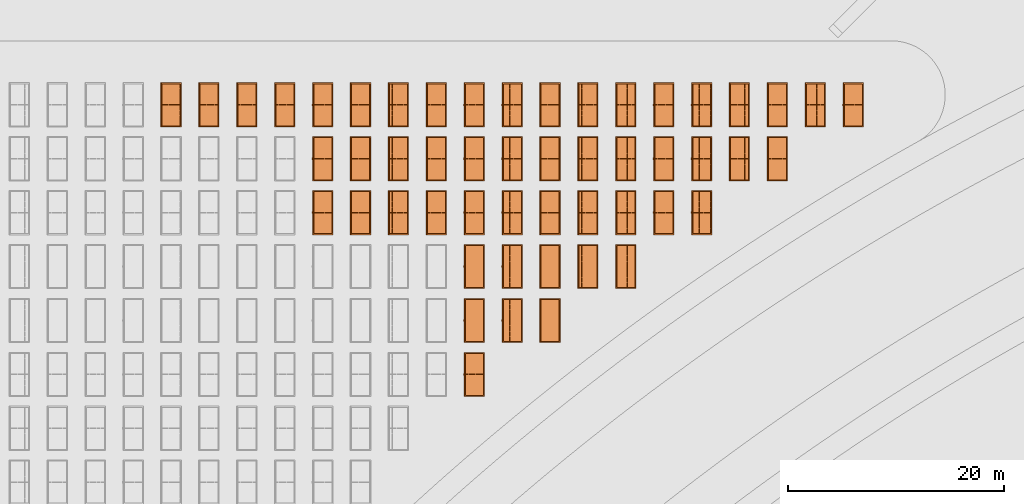
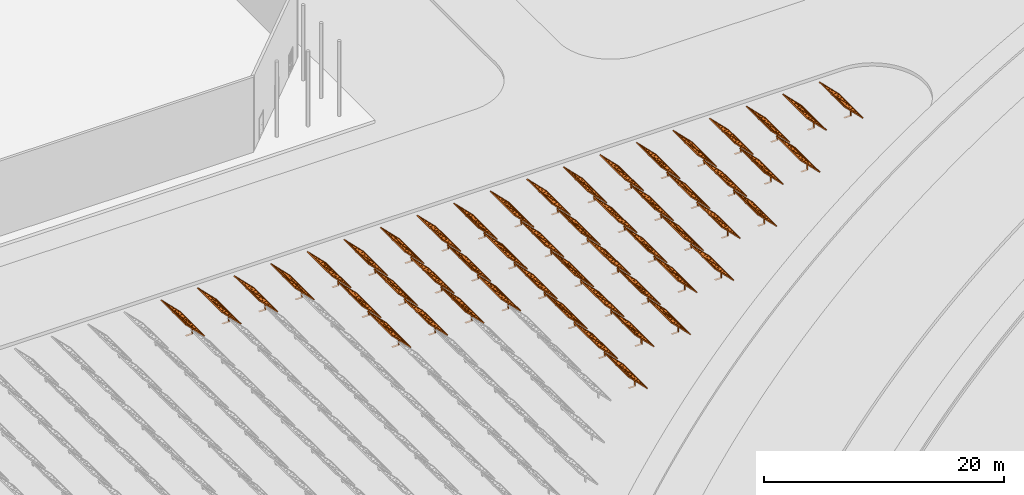
# One storey, part 38 of 39: 52 proxies.
"""IFC2X3 building model written with IfcOpenShell, lengths in millimetres."""

from ifc_helpers import new_model, entity, si_unit, converted_unit, derived_unit, direction, frame, frame_2d, origin, origin_2d_with_axis, place, context, subcontext, project, spatial, polyline, rectangle, outline, extrude, source, transform, mapped, material, material_list, element, save


model = new_model("IFC2X3")

# Units and contexts
model_context = context("Model", 3, precision=1e-06, world=origin(), true_north=direction((2.0, 6.12303176911189e-17, 1.0)))
context_of_model = context(None, 3, precision=1e-06, world=origin(), true_north=direction((2.0, 6.12303176911189e-17, 1.0)))
body_context = subcontext(model_context, "Body", "Model", "MODEL_VIEW")
ifc_project = project(units=[si_unit("LENGTHUNIT", "METRE", prefix="MILLI"), si_unit("AREAUNIT", "SQUARE_METRE", prefix="MILLI"), si_unit("VOLUMEUNIT", "CUBIC_METRE", prefix="MILLI"), converted_unit("PLANEANGLEUNIT", "DEGREE", entity("IfcRatioMeasure", 0.0174532925199433), si_unit("PLANEANGLEUNIT", "RADIAN"), dimensions=[0, 0, 0, 0, 0, 0, 0]), si_unit("MASSUNIT", "GRAM", prefix="KILO"), si_unit("TIMEUNIT", "SECOND"), si_unit("THERMODYNAMICTEMPERATUREUNIT", "KELVIN"), derived_unit("THERMALTRANSMITTANCEUNIT", [(si_unit("MASSUNIT", "GRAM", prefix="KILO"), 1), (si_unit("THERMODYNAMICTEMPERATUREUNIT", "KELVIN"), -1), (si_unit("TIMEUNIT", "SECOND"), -3)]), derived_unit("VOLUMETRICFLOWRATEUNIT", [(si_unit("LENGTHUNIT", "METRE"), 3), (si_unit("TIMEUNIT", "SECOND"), -1)])], contexts=[model_context, context_of_model])

# Site, building, storey
site_placement = place(None, origin())
site = spatial("IfcSite", under=ifc_project, at=site_placement, CompositionType="ELEMENT")
building_placement = place(site_placement, origin())
building = spatial("IfcBuilding", under=site, at=building_placement, CompositionType="ELEMENT")
storey_placement = place(building_placement, frame((0.0, 0.0, 4000.0)))
storey = spatial("IfcBuildingStorey", under=building, at=storey_placement, Name="Level 2", CompositionType="ELEMENT", Elevation=4000.0)

# Proxies
ifc_material_1 = material(Name="Stand-Steel")
ifc_material_2 = material(Name="Aluminium")
ifc_material_3 = material(Name="Glass")
ifc_material_list_1 = material_list([ifc_material_1, ifc_material_2, ifc_material_3])
shared_shape = source(origin(), body_context, "Body", "SweptSolid", [
    extrude(outline(polyline([(-629.526235435404, -220.0), (329.763117717702, -220.0), (329.763117717703, 410.0), (299.763117717703, 410.0), (299.763117717702, -190.0), (-629.526235435404, -190.0), (-629.526235435404, -220.0)])), frame((-190.00003127179, -100.0, 299.763117717707), z_axis=(0.0, 1.0, 0.0), x_axis=(0.0, 0.0, -1.0)), (0.0, 0.0, 1.0), 200.0),
    extrude(rectangle(XDim=20.0000000000001, YDim=200.0, at=frame_2d((0.0, -7.105427357601e-14), x_axis=(0.0, 1.0))), frame((-7.07109908365613, 0.0, 922.21828534124), z_axis=(-0.70710678118654, 0.0, 0.707106781186555), x_axis=(0.0, 1.0, 0.0)), (0.0, 0.0, 1.0), 2600.0),
    extrude(rectangle(XDim=24.9999999999997, YDim=24.9999999999999, at=frame_2d((2.87769807982841e-13, -9.50350909079134e-14), x_axis=(1.0, 0.0))), frame((-1449.56292018118, -1950.0, 2449.57494522722), z_axis=(0.0, 1.0, 0.0), x_axis=(-0.707106781186548, 0.0, -0.707106781186548)), (0.0, 0.0, 1.0), 3900.0),
    extrude(rectangle(XDim=24.9999999999999, YDim=25.0000000000001, at=origin_2d_with_axis()), frame((-1096.0095295879, -1950.0, 2096.02155463395), z_axis=(0.0, 1.0, 0.0), x_axis=(-0.707106781186542, 0.0, -0.707106781186553)), (0.0, 0.0, 1.0), 3900.0),
    extrude(rectangle(XDim=24.9999999999999, YDim=25.0000000000001, at=origin_2d_with_axis()), frame((-742.456138994631, -1950.0, 1742.46816404067), z_axis=(0.0, 1.0, 0.0), x_axis=(-0.707106781186542, 0.0, -0.707106781186553)), (0.0, 0.0, 1.0), 3900.0),
    extrude(rectangle(XDim=25.0, YDim=24.9999999999997, at=frame_2d((-7.19424519957101e-14, 1.19904086659517e-13), x_axis=(1.0, 0.0))), frame((-388.902748401358, -1950.0, 1388.9147734474), z_axis=(0.0, 1.0, 0.0), x_axis=(-0.707106781186545, 0.0, -0.70710678118655)), (0.0, 0.0, 1.0), 3900.0),
    extrude(rectangle(XDim=25.0000000000002, YDim=25.0, at=frame_2d((1.35891298214119e-13, 6.21724893790088e-15), x_axis=(0.0, 1.0))), frame((-35.3553703311048, 1500.0, 1035.35537033109), z_axis=(-0.707106781186544, 0.0, 0.707106781186551), x_axis=(0.0, 1.0, 0.0)), (0.0, 0.0, 1.0), 2440.0),
    extrude(rectangle(XDim=25.0000000000002, YDim=25.0, at=frame_2d((0.0, 1.77635683940025e-15), x_axis=(0.0, 1.0))), frame((-35.3553703311059, 1000.0, 1035.35537033109), z_axis=(-0.707106781186546, 0.0, 0.707106781186549), x_axis=(0.0, 1.0, 0.0)), (0.0, 0.0, 1.0), 2440.0),
    extrude(rectangle(XDim=25.0000000000002, YDim=25.0, at=frame_2d((0.0, 8.43769498715119e-14), x_axis=(0.0, 1.0))), frame((-26.5165355662756, 0.0, 1044.19420509593), z_axis=(-0.707106781186546, 0.0, 0.707106781186549), x_axis=(0.0, -1.0, 0.0)), (0.0, 0.0, 1.0), 2440.0),
    extrude(rectangle(XDim=25.0000000000002, YDim=25.0, at=frame_2d((0.0, 8.88178419700125e-16), x_axis=(0.0, 1.0))), frame((-35.3553703311065, 500.0, 1035.35537033109), z_axis=(-0.707106781186546, 0.0, 0.707106781186549), x_axis=(0.0, 1.0, 0.0)), (0.0, 0.0, 1.0), 2440.0),
    extrude(rectangle(XDim=25.0000000000002, YDim=25.0, at=frame_2d((0.0, 8.88178419700125e-16), x_axis=(0.0, 1.0))), frame((-35.3553703311086, -500.0, 1035.35537033109), z_axis=(-0.707106781186546, 0.0, 0.707106781186549), x_axis=(0.0, 1.0, 0.0)), (0.0, 0.0, 1.0), 2440.0),
    extrude(rectangle(XDim=25.0000000000002, YDim=25.0, at=frame_2d((0.0, 8.88178419700125e-16), x_axis=(0.0, 1.0))), frame((-35.3553703311095, -1000.0, 1035.35537033109), z_axis=(-0.707106781186546, 0.0, 0.707106781186549), x_axis=(0.0, 1.0, 0.0)), (0.0, 0.0, 1.0), 2440.0),
    extrude(rectangle(XDim=25.0000000000002, YDim=25.0, at=frame_2d((1.35891298214119e-13, 1.77635683940025e-15), x_axis=(0.0, 1.0))), frame((-35.3553703311107, -1500.0, 1035.35537033109), z_axis=(-0.707106781186546, 0.0, 0.707106781186549), x_axis=(0.0, 1.0, 0.0)), (0.0, 0.0, 1.0), 2440.0),
    extrude(rectangle(XDim=2400.0, YDim=11.9999999999994, at=frame_2d((-1.13686837721616e-13, 2.02948768901479e-13), x_axis=(1.0, 0.0))), frame((-883.883507754966, -1950.0, 1883.88350775495), z_axis=(0.0, 1.0, 0.0), x_axis=(0.707106781186546, 0.0, -0.707106781186549)), (0.0, 0.0, 1.0), 3900.0),
    extrude(outline(polyline([(-2050.0, -1300.0), (2050.0, -1300.0), (2050.0, 1300.0), (-2050.0, 1300.0), (-2050.0, -1300.0)]), holes=[polyline([(1950.0, -1200.0), (-1950.0, -1200.0), (-1950.0, 1200.0), (1950.0, 1200.0), (1950.0, -1200.0)])]), frame((-919.238846814293, 0.0, 1848.52816869563), z_axis=(0.707106781186554, 0.0, 0.707106781186541), x_axis=(0.0, 1.0, 0.0)), (0.0, 0.0, 1.0), 99.9999999999898),
])
proxy_1_placement = place(storey_placement, frame((-76070.1519924236, 685144.680552408, 30.0)))
element("IfcBuildingElementProxy", 1, at=proxy_1_placement, inside=storey, material=ifc_material_list_1, Name="Solar Panel_4000X2500:Solar Panel_4000X2500", ObjectType="Solar Panel_4000X2500", CompositionType="ELEMENT", context=body_context, shape_type="MappedRepresentation", body=[
    mapped(shared_shape, transform((0.0, 0.0, 0.0), scale=1.0)),
])
ifc_material_list_2 = material_list([ifc_material_1, ifc_material_2, ifc_material_3])
proxy_2_placement = place(storey_placement, frame((-72555.1416206938, 685144.680552408, 30.0)))
element("IfcBuildingElementProxy", 2, at=proxy_2_placement, inside=storey, material=ifc_material_list_2, Name="Solar Panel_4000X2500:Solar Panel_4000X2500", ObjectType="Solar Panel_4000X2500", CompositionType="ELEMENT", context=body_context, shape_type="MappedRepresentation", body=[
    mapped(shared_shape, transform((0.0, 0.0, 0.0), scale=1.0)),
])
ifc_material_list_3 = material_list([ifc_material_1, ifc_material_2, ifc_material_3])
proxy_3_placement = place(storey_placement, frame((-69040.131248964, 685144.680552408, 30.0)))
element("IfcBuildingElementProxy", 3, at=proxy_3_placement, inside=storey, material=ifc_material_list_3, Name="Solar Panel_4000X2500:Solar Panel_4000X2500", ObjectType="Solar Panel_4000X2500", CompositionType="ELEMENT", context=body_context, shape_type="MappedRepresentation", body=[
    mapped(shared_shape, transform((0.0, 0.0, 0.0), scale=1.0)),
])
ifc_material_list_4 = material_list([ifc_material_1, ifc_material_2, ifc_material_3])
proxy_4_placement = place(storey_placement, frame((-65525.1208772342, 685144.680552408, 30.0)))
element("IfcBuildingElementProxy", 4, at=proxy_4_placement, inside=storey, material=ifc_material_list_4, Name="Solar Panel_4000X2500:Solar Panel_4000X2500", ObjectType="Solar Panel_4000X2500", CompositionType="ELEMENT", context=body_context, shape_type="MappedRepresentation", body=[
    mapped(shared_shape, transform((0.0, 0.0, 0.0), scale=1.0)),
])
ifc_material_list_5 = material_list([ifc_material_1, ifc_material_2, ifc_material_3])
proxy_5_placement = place(storey_placement, frame((-62010.1105055045, 675144.680552408, 30.0)))
element("IfcBuildingElementProxy", 5, at=proxy_5_placement, inside=storey, material=ifc_material_list_5, Name="Solar Panel_4000X2500:Solar Panel_4000X2500", ObjectType="Solar Panel_4000X2500", CompositionType="ELEMENT", context=body_context, shape_type="MappedRepresentation", body=[
    mapped(shared_shape, transform((0.0, 0.0, 0.0), scale=1.0)),
])
ifc_material_list_6 = material_list([ifc_material_1, ifc_material_2, ifc_material_3])
proxy_6_placement = place(storey_placement, frame((-58495.1001337747, 675144.680552408, 30.0)))
element("IfcBuildingElementProxy", 6, at=proxy_6_placement, inside=storey, material=ifc_material_list_6, Name="Solar Panel_4000X2500:Solar Panel_4000X2500", ObjectType="Solar Panel_4000X2500", CompositionType="ELEMENT", context=body_context, shape_type="MappedRepresentation", body=[
    mapped(shared_shape, transform((0.0, 0.0, 0.0), scale=1.0)),
])
ifc_material_list_7 = material_list([ifc_material_1, ifc_material_2, ifc_material_3])
proxy_7_placement = place(storey_placement, frame((-54980.0897620449, 675144.680552408, 30.0)))
element("IfcBuildingElementProxy", 7, at=proxy_7_placement, inside=storey, material=ifc_material_list_7, Name="Solar Panel_4000X2500:Solar Panel_4000X2500", ObjectType="Solar Panel_4000X2500", CompositionType="ELEMENT", context=body_context, shape_type="MappedRepresentation", body=[
    mapped(shared_shape, transform((0.0, 0.0, 0.0), scale=1.0)),
])
ifc_material_list_8 = material_list([ifc_material_1, ifc_material_2, ifc_material_3])
proxy_8_placement = place(storey_placement, frame((-51465.0793903151, 675144.680552408, 30.0)))
element("IfcBuildingElementProxy", 8, at=proxy_8_placement, inside=storey, material=ifc_material_list_8, Name="Solar Panel_4000X2500:Solar Panel_4000X2500", ObjectType="Solar Panel_4000X2500", CompositionType="ELEMENT", context=body_context, shape_type="MappedRepresentation", body=[
    mapped(shared_shape, transform((0.0, 0.0, 0.0), scale=1.0)),
])
ifc_material_list_9 = material_list([ifc_material_1, ifc_material_2, ifc_material_3])
proxy_9_placement = place(storey_placement, frame((-62010.1105055045, 680144.680552408, 30.0)))
element("IfcBuildingElementProxy", 9, at=proxy_9_placement, inside=storey, material=ifc_material_list_9, Name="Solar Panel_4000X2500:Solar Panel_4000X2500", ObjectType="Solar Panel_4000X2500", CompositionType="ELEMENT", context=body_context, shape_type="MappedRepresentation", body=[
    mapped(shared_shape, transform((0.0, 0.0, 0.0), scale=1.0)),
])
ifc_material_list_10 = material_list([ifc_material_1, ifc_material_2, ifc_material_3])
proxy_10_placement = place(storey_placement, frame((-58495.1001337747, 680144.680552408, 30.0)))
element("IfcBuildingElementProxy", 10, at=proxy_10_placement, inside=storey, material=ifc_material_list_10, Name="Solar Panel_4000X2500:Solar Panel_4000X2500", ObjectType="Solar Panel_4000X2500", CompositionType="ELEMENT", context=body_context, shape_type="MappedRepresentation", body=[
    mapped(shared_shape, transform((0.0, 0.0, 0.0), scale=1.0)),
])
ifc_material_list_11 = material_list([ifc_material_1, ifc_material_2, ifc_material_3])
proxy_11_placement = place(storey_placement, frame((-54980.0897620449, 680144.680552408, 30.0)))
element("IfcBuildingElementProxy", 11, at=proxy_11_placement, inside=storey, material=ifc_material_list_11, Name="Solar Panel_4000X2500:Solar Panel_4000X2500", ObjectType="Solar Panel_4000X2500", CompositionType="ELEMENT", context=body_context, shape_type="MappedRepresentation", body=[
    mapped(shared_shape, transform((0.0, 0.0, 0.0), scale=1.0)),
])
ifc_material_list_12 = material_list([ifc_material_1, ifc_material_2, ifc_material_3])
proxy_12_placement = place(storey_placement, frame((-51465.0793903151, 680144.680552408, 30.0)))
element("IfcBuildingElementProxy", 12, at=proxy_12_placement, inside=storey, material=ifc_material_list_12, Name="Solar Panel_4000X2500:Solar Panel_4000X2500", ObjectType="Solar Panel_4000X2500", CompositionType="ELEMENT", context=body_context, shape_type="MappedRepresentation", body=[
    mapped(shared_shape, transform((0.0, 0.0, 0.0), scale=1.0)),
])
ifc_material_list_13 = material_list([ifc_material_1, ifc_material_2, ifc_material_3])
proxy_13_placement = place(storey_placement, frame((-62010.1105055044, 685144.680552408, 30.0)))
element("IfcBuildingElementProxy", 13, at=proxy_13_placement, inside=storey, material=ifc_material_list_13, Name="Solar Panel_4000X2500:Solar Panel_4000X2500", ObjectType="Solar Panel_4000X2500", CompositionType="ELEMENT", context=body_context, shape_type="MappedRepresentation", body=[
    mapped(shared_shape, transform((0.0, 0.0, 0.0), scale=1.0)),
])
ifc_material_list_14 = material_list([ifc_material_1, ifc_material_2, ifc_material_3])
proxy_14_placement = place(storey_placement, frame((-58495.1001337746, 685144.680552408, 30.0)))
element("IfcBuildingElementProxy", 14, at=proxy_14_placement, inside=storey, material=ifc_material_list_14, Name="Solar Panel_4000X2500:Solar Panel_4000X2500", ObjectType="Solar Panel_4000X2500", CompositionType="ELEMENT", context=body_context, shape_type="MappedRepresentation", body=[
    mapped(shared_shape, transform((0.0, 0.0, 0.0), scale=1.0)),
])
ifc_material_list_15 = material_list([ifc_material_1, ifc_material_2, ifc_material_3])
proxy_15_placement = place(storey_placement, frame((-54980.0897620449, 685144.680552408, 30.0)))
element("IfcBuildingElementProxy", 15, at=proxy_15_placement, inside=storey, material=ifc_material_list_15, Name="Solar Panel_4000X2500:Solar Panel_4000X2500", ObjectType="Solar Panel_4000X2500", CompositionType="ELEMENT", context=body_context, shape_type="MappedRepresentation", body=[
    mapped(shared_shape, transform((0.0, 0.0, 0.0), scale=1.0)),
])
ifc_material_list_16 = material_list([ifc_material_1, ifc_material_2, ifc_material_3])
proxy_16_placement = place(storey_placement, frame((-51465.0793903151, 685144.680552408, 30.0)))
element("IfcBuildingElementProxy", 16, at=proxy_16_placement, inside=storey, material=ifc_material_list_16, Name="Solar Panel_4000X2500:Solar Panel_4000X2500", ObjectType="Solar Panel_4000X2500", CompositionType="ELEMENT", context=body_context, shape_type="MappedRepresentation", body=[
    mapped(shared_shape, transform((0.0, 0.0, 0.0), scale=1.0)),
])
ifc_material_list_17 = material_list([ifc_material_1, ifc_material_2, ifc_material_3])
proxy_17_placement = place(storey_placement, frame((-47950.0690185853, 660144.680552408, 30.0)))
element("IfcBuildingElementProxy", 17, at=proxy_17_placement, inside=storey, material=ifc_material_list_17, Name="Solar Panel_4000X2500:Solar Panel_4000X2500", ObjectType="Solar Panel_4000X2500", CompositionType="ELEMENT", context=body_context, shape_type="MappedRepresentation", body=[
    mapped(shared_shape, transform((0.0, 0.0, 0.0), scale=1.0)),
])
ifc_material_list_18 = material_list([ifc_material_1, ifc_material_2, ifc_material_3])
proxy_18_placement = place(storey_placement, frame((-47950.0690185853, 665144.680552408, 30.0)))
element("IfcBuildingElementProxy", 18, at=proxy_18_placement, inside=storey, material=ifc_material_list_18, Name="Solar Panel_4000X2500:Solar Panel_4000X2500", ObjectType="Solar Panel_4000X2500", CompositionType="ELEMENT", context=body_context, shape_type="MappedRepresentation", body=[
    mapped(shared_shape, transform((0.0, 0.0, 0.0), scale=1.0)),
])
ifc_material_list_19 = material_list([ifc_material_1, ifc_material_2, ifc_material_3])
proxy_19_placement = place(storey_placement, frame((-44435.0586468555, 665144.680552408, 30.0)))
element("IfcBuildingElementProxy", 19, at=proxy_19_placement, inside=storey, material=ifc_material_list_19, Name="Solar Panel_4000X2500:Solar Panel_4000X2500", ObjectType="Solar Panel_4000X2500", CompositionType="ELEMENT", context=body_context, shape_type="MappedRepresentation", body=[
    mapped(shared_shape, transform((0.0, 0.0, 0.0), scale=1.0)),
])
ifc_material_list_20 = material_list([ifc_material_1, ifc_material_2, ifc_material_3])
proxy_20_placement = place(storey_placement, frame((-40920.0482751257, 665144.680552408, 30.0)))
element("IfcBuildingElementProxy", 20, at=proxy_20_placement, inside=storey, material=ifc_material_list_20, Name="Solar Panel_4000X2500:Solar Panel_4000X2500", ObjectType="Solar Panel_4000X2500", CompositionType="ELEMENT", context=body_context, shape_type="MappedRepresentation", body=[
    mapped(shared_shape, transform((0.0, 0.0, 0.0), scale=1.0)),
])
ifc_material_list_21 = material_list([ifc_material_1, ifc_material_2, ifc_material_3])
proxy_21_placement = place(storey_placement, frame((-47950.0690185853, 670144.680552408, 30.0)))
element("IfcBuildingElementProxy", 21, at=proxy_21_placement, inside=storey, material=ifc_material_list_21, Name="Solar Panel_4000X2500:Solar Panel_4000X2500", ObjectType="Solar Panel_4000X2500", CompositionType="ELEMENT", context=body_context, shape_type="MappedRepresentation", body=[
    mapped(shared_shape, transform((0.0, 0.0, 0.0), scale=1.0)),
])
ifc_material_list_22 = material_list([ifc_material_1, ifc_material_2, ifc_material_3])
proxy_22_placement = place(storey_placement, frame((-44435.0586468555, 670144.680552408, 30.0)))
element("IfcBuildingElementProxy", 22, at=proxy_22_placement, inside=storey, material=ifc_material_list_22, Name="Solar Panel_4000X2500:Solar Panel_4000X2500", ObjectType="Solar Panel_4000X2500", CompositionType="ELEMENT", context=body_context, shape_type="MappedRepresentation", body=[
    mapped(shared_shape, transform((0.0, 0.0, 0.0), scale=1.0)),
])
ifc_material_list_23 = material_list([ifc_material_1, ifc_material_2, ifc_material_3])
proxy_23_placement = place(storey_placement, frame((-40920.0482751257, 670144.680552408, 30.0)))
element("IfcBuildingElementProxy", 23, at=proxy_23_placement, inside=storey, material=ifc_material_list_23, Name="Solar Panel_4000X2500:Solar Panel_4000X2500", ObjectType="Solar Panel_4000X2500", CompositionType="ELEMENT", context=body_context, shape_type="MappedRepresentation", body=[
    mapped(shared_shape, transform((0.0, 0.0, 0.0), scale=1.0)),
])
ifc_material_list_24 = material_list([ifc_material_1, ifc_material_2, ifc_material_3])
proxy_24_placement = place(storey_placement, frame((-37405.0379033959, 670144.680552408, 30.0)))
element("IfcBuildingElementProxy", 24, at=proxy_24_placement, inside=storey, material=ifc_material_list_24, Name="Solar Panel_4000X2500:Solar Panel_4000X2500", ObjectType="Solar Panel_4000X2500", CompositionType="ELEMENT", context=body_context, shape_type="MappedRepresentation", body=[
    mapped(shared_shape, transform((0.0, 0.0, 0.0), scale=1.0)),
])
ifc_material_list_25 = material_list([ifc_material_1, ifc_material_2, ifc_material_3])
proxy_25_placement = place(storey_placement, frame((-47950.0690185853, 675144.680552408, 30.0)))
element("IfcBuildingElementProxy", 25, at=proxy_25_placement, inside=storey, material=ifc_material_list_25, Name="Solar Panel_4000X2500:Solar Panel_4000X2500", ObjectType="Solar Panel_4000X2500", CompositionType="ELEMENT", context=body_context, shape_type="MappedRepresentation", body=[
    mapped(shared_shape, transform((0.0, 0.0, 0.0), scale=1.0)),
])
ifc_material_list_26 = material_list([ifc_material_1, ifc_material_2, ifc_material_3])
proxy_26_placement = place(storey_placement, frame((-44435.0586468555, 675144.680552408, 30.0)))
element("IfcBuildingElementProxy", 26, at=proxy_26_placement, inside=storey, material=ifc_material_list_26, Name="Solar Panel_4000X2500:Solar Panel_4000X2500", ObjectType="Solar Panel_4000X2500", CompositionType="ELEMENT", context=body_context, shape_type="MappedRepresentation", body=[
    mapped(shared_shape, transform((0.0, 0.0, 0.0), scale=1.0)),
])
ifc_material_list_27 = material_list([ifc_material_1, ifc_material_2, ifc_material_3])
proxy_27_placement = place(storey_placement, frame((-40920.0482751257, 675144.680552408, 30.0)))
element("IfcBuildingElementProxy", 27, at=proxy_27_placement, inside=storey, material=ifc_material_list_27, Name="Solar Panel_4000X2500:Solar Panel_4000X2500", ObjectType="Solar Panel_4000X2500", CompositionType="ELEMENT", context=body_context, shape_type="MappedRepresentation", body=[
    mapped(shared_shape, transform((0.0, 0.0, 0.0), scale=1.0)),
])
ifc_material_list_28 = material_list([ifc_material_1, ifc_material_2, ifc_material_3])
proxy_28_placement = place(storey_placement, frame((-37405.0379033959, 675144.680552408, 30.0)))
element("IfcBuildingElementProxy", 28, at=proxy_28_placement, inside=storey, material=ifc_material_list_28, Name="Solar Panel_4000X2500:Solar Panel_4000X2500", ObjectType="Solar Panel_4000X2500", CompositionType="ELEMENT", context=body_context, shape_type="MappedRepresentation", body=[
    mapped(shared_shape, transform((0.0, 0.0, 0.0), scale=1.0)),
])
ifc_material_list_29 = material_list([ifc_material_1, ifc_material_2, ifc_material_3])
proxy_29_placement = place(storey_placement, frame((-47950.0690185853, 680144.680552408, 30.0)))
element("IfcBuildingElementProxy", 29, at=proxy_29_placement, inside=storey, material=ifc_material_list_29, Name="Solar Panel_4000X2500:Solar Panel_4000X2500", ObjectType="Solar Panel_4000X2500", CompositionType="ELEMENT", context=body_context, shape_type="MappedRepresentation", body=[
    mapped(shared_shape, transform((0.0, 0.0, 0.0), scale=1.0)),
])
ifc_material_list_30 = material_list([ifc_material_1, ifc_material_2, ifc_material_3])
proxy_30_placement = place(storey_placement, frame((-44435.0586468555, 680144.680552408, 30.0)))
element("IfcBuildingElementProxy", 30, at=proxy_30_placement, inside=storey, material=ifc_material_list_30, Name="Solar Panel_4000X2500:Solar Panel_4000X2500", ObjectType="Solar Panel_4000X2500", CompositionType="ELEMENT", context=body_context, shape_type="MappedRepresentation", body=[
    mapped(shared_shape, transform((0.0, 0.0, 0.0), scale=1.0)),
])
ifc_material_list_31 = material_list([ifc_material_1, ifc_material_2, ifc_material_3])
proxy_31_placement = place(storey_placement, frame((-40920.0482751257, 680144.680552408, 30.0)))
element("IfcBuildingElementProxy", 31, at=proxy_31_placement, inside=storey, material=ifc_material_list_31, Name="Solar Panel_4000X2500:Solar Panel_4000X2500", ObjectType="Solar Panel_4000X2500", CompositionType="ELEMENT", context=body_context, shape_type="MappedRepresentation", body=[
    mapped(shared_shape, transform((0.0, 0.0, 0.0), scale=1.0)),
])
ifc_material_list_32 = material_list([ifc_material_1, ifc_material_2, ifc_material_3])
proxy_32_placement = place(storey_placement, frame((-37405.0379033959, 680144.680552408, 30.0)))
element("IfcBuildingElementProxy", 32, at=proxy_32_placement, inside=storey, material=ifc_material_list_32, Name="Solar Panel_4000X2500:Solar Panel_4000X2500", ObjectType="Solar Panel_4000X2500", CompositionType="ELEMENT", context=body_context, shape_type="MappedRepresentation", body=[
    mapped(shared_shape, transform((0.0, 0.0, 0.0), scale=1.0)),
])
ifc_material_list_33 = material_list([ifc_material_1, ifc_material_2, ifc_material_3])
proxy_33_placement = place(storey_placement, frame((-47950.0690185853, 685144.680552408, 30.0)))
element("IfcBuildingElementProxy", 33, at=proxy_33_placement, inside=storey, material=ifc_material_list_33, Name="Solar Panel_4000X2500:Solar Panel_4000X2500", ObjectType="Solar Panel_4000X2500", CompositionType="ELEMENT", context=body_context, shape_type="MappedRepresentation", body=[
    mapped(shared_shape, transform((0.0, 0.0, 0.0), scale=1.0)),
])
ifc_material_list_34 = material_list([ifc_material_1, ifc_material_2, ifc_material_3])
proxy_34_placement = place(storey_placement, frame((-44435.0586468555, 685144.680552408, 30.0)))
element("IfcBuildingElementProxy", 34, at=proxy_34_placement, inside=storey, material=ifc_material_list_34, Name="Solar Panel_4000X2500:Solar Panel_4000X2500", ObjectType="Solar Panel_4000X2500", CompositionType="ELEMENT", context=body_context, shape_type="MappedRepresentation", body=[
    mapped(shared_shape, transform((0.0, 0.0, 0.0), scale=1.0)),
])
ifc_material_list_35 = material_list([ifc_material_1, ifc_material_2, ifc_material_3])
proxy_35_placement = place(storey_placement, frame((-40920.0482751257, 685144.680552408, 30.0)))
element("IfcBuildingElementProxy", 35, at=proxy_35_placement, inside=storey, material=ifc_material_list_35, Name="Solar Panel_4000X2500:Solar Panel_4000X2500", ObjectType="Solar Panel_4000X2500", CompositionType="ELEMENT", context=body_context, shape_type="MappedRepresentation", body=[
    mapped(shared_shape, transform((0.0, 0.0, 0.0), scale=1.0)),
])
ifc_material_list_36 = material_list([ifc_material_1, ifc_material_2, ifc_material_3])
proxy_36_placement = place(storey_placement, frame((-37405.0379033959, 685144.680552408, 30.0)))
element("IfcBuildingElementProxy", 36, at=proxy_36_placement, inside=storey, material=ifc_material_list_36, Name="Solar Panel_4000X2500:Solar Panel_4000X2500", ObjectType="Solar Panel_4000X2500", CompositionType="ELEMENT", context=body_context, shape_type="MappedRepresentation", body=[
    mapped(shared_shape, transform((0.0, 0.0, 0.0), scale=1.0)),
])
ifc_material_list_37 = material_list([ifc_material_1, ifc_material_2, ifc_material_3])
proxy_37_placement = place(storey_placement, frame((-33890.0275316662, 675144.680552408, 30.0)))
element("IfcBuildingElementProxy", 37, at=proxy_37_placement, inside=storey, material=ifc_material_list_37, Name="Solar Panel_4000X2500:Solar Panel_4000X2500", ObjectType="Solar Panel_4000X2500", CompositionType="ELEMENT", context=body_context, shape_type="MappedRepresentation", body=[
    mapped(shared_shape, transform((0.0, 0.0, 0.0), scale=1.0)),
])
ifc_material_list_38 = material_list([ifc_material_1, ifc_material_2, ifc_material_3])
proxy_38_placement = place(storey_placement, frame((-30375.0171599364, 675144.680552408, 30.0)))
element("IfcBuildingElementProxy", 38, at=proxy_38_placement, inside=storey, material=ifc_material_list_38, Name="Solar Panel_4000X2500:Solar Panel_4000X2500", ObjectType="Solar Panel_4000X2500", CompositionType="ELEMENT", context=body_context, shape_type="MappedRepresentation", body=[
    mapped(shared_shape, transform((0.0, 0.0, 0.0), scale=1.0)),
])
ifc_material_list_39 = material_list([ifc_material_1, ifc_material_2, ifc_material_3])
proxy_39_placement = place(storey_placement, frame((-26860.0067882066, 675144.680552408, 30.0)))
element("IfcBuildingElementProxy", 39, at=proxy_39_placement, inside=storey, material=ifc_material_list_39, Name="Solar Panel_4000X2500:Solar Panel_4000X2500", ObjectType="Solar Panel_4000X2500", CompositionType="ELEMENT", context=body_context, shape_type="MappedRepresentation", body=[
    mapped(shared_shape, transform((0.0, 0.0, 0.0), scale=1.0)),
])
ifc_material_list_40 = material_list([ifc_material_1, ifc_material_2, ifc_material_3])
proxy_40_placement = place(storey_placement, frame((-33890.0275316662, 680144.680552408, 30.0)))
element("IfcBuildingElementProxy", 40, at=proxy_40_placement, inside=storey, material=ifc_material_list_40, Name="Solar Panel_4000X2500:Solar Panel_4000X2500", ObjectType="Solar Panel_4000X2500", CompositionType="ELEMENT", context=body_context, shape_type="MappedRepresentation", body=[
    mapped(shared_shape, transform((0.0, 0.0, 0.0), scale=1.0)),
])
ifc_material_list_41 = material_list([ifc_material_1, ifc_material_2, ifc_material_3])
proxy_41_placement = place(storey_placement, frame((-30375.0171599364, 680144.680552408, 30.0)))
element("IfcBuildingElementProxy", 41, at=proxy_41_placement, inside=storey, material=ifc_material_list_41, Name="Solar Panel_4000X2500:Solar Panel_4000X2500", ObjectType="Solar Panel_4000X2500", CompositionType="ELEMENT", context=body_context, shape_type="MappedRepresentation", body=[
    mapped(shared_shape, transform((0.0, 0.0, 0.0), scale=1.0)),
])
ifc_material_list_42 = material_list([ifc_material_1, ifc_material_2, ifc_material_3])
proxy_42_placement = place(storey_placement, frame((-26860.0067882066, 680144.680552408, 30.0)))
element("IfcBuildingElementProxy", 42, at=proxy_42_placement, inside=storey, material=ifc_material_list_42, Name="Solar Panel_4000X2500:Solar Panel_4000X2500", ObjectType="Solar Panel_4000X2500", CompositionType="ELEMENT", context=body_context, shape_type="MappedRepresentation", body=[
    mapped(shared_shape, transform((0.0, 0.0, 0.0), scale=1.0)),
])
ifc_material_list_43 = material_list([ifc_material_1, ifc_material_2, ifc_material_3])
proxy_43_placement = place(storey_placement, frame((-23344.9964164768, 680144.680552408, 30.0)))
element("IfcBuildingElementProxy", 43, at=proxy_43_placement, inside=storey, material=ifc_material_list_43, Name="Solar Panel_4000X2500:Solar Panel_4000X2500", ObjectType="Solar Panel_4000X2500", CompositionType="ELEMENT", context=body_context, shape_type="MappedRepresentation", body=[
    mapped(shared_shape, transform((0.0, 0.0, 0.0), scale=1.0)),
])
ifc_material_list_44 = material_list([ifc_material_1, ifc_material_2, ifc_material_3])
proxy_44_placement = place(storey_placement, frame((-33890.0275316661, 685144.680552408, 30.0)))
element("IfcBuildingElementProxy", 44, at=proxy_44_placement, inside=storey, material=ifc_material_list_44, Name="Solar Panel_4000X2500:Solar Panel_4000X2500", ObjectType="Solar Panel_4000X2500", CompositionType="ELEMENT", context=body_context, shape_type="MappedRepresentation", body=[
    mapped(shared_shape, transform((0.0, 0.0, 0.0), scale=1.0)),
])
ifc_material_list_45 = material_list([ifc_material_1, ifc_material_2, ifc_material_3])
proxy_45_placement = place(storey_placement, frame((-30375.0171599363, 685144.680552408, 30.0)))
element("IfcBuildingElementProxy", 45, at=proxy_45_placement, inside=storey, material=ifc_material_list_45, Name="Solar Panel_4000X2500:Solar Panel_4000X2500", ObjectType="Solar Panel_4000X2500", CompositionType="ELEMENT", context=body_context, shape_type="MappedRepresentation", body=[
    mapped(shared_shape, transform((0.0, 0.0, 0.0), scale=1.0)),
])
ifc_material_list_46 = material_list([ifc_material_1, ifc_material_2, ifc_material_3])
proxy_46_placement = place(storey_placement, frame((-26860.0067882066, 685144.680552408, 30.0)))
element("IfcBuildingElementProxy", 46, at=proxy_46_placement, inside=storey, material=ifc_material_list_46, Name="Solar Panel_4000X2500:Solar Panel_4000X2500", ObjectType="Solar Panel_4000X2500", CompositionType="ELEMENT", context=body_context, shape_type="MappedRepresentation", body=[
    mapped(shared_shape, transform((0.0, 0.0, 0.0), scale=1.0)),
])
ifc_material_list_47 = material_list([ifc_material_1, ifc_material_2, ifc_material_3])
proxy_47_placement = place(storey_placement, frame((-23344.9964164768, 685144.680552408, 30.0)))
element("IfcBuildingElementProxy", 47, at=proxy_47_placement, inside=storey, material=ifc_material_list_47, Name="Solar Panel_4000X2500:Solar Panel_4000X2500", ObjectType="Solar Panel_4000X2500", CompositionType="ELEMENT", context=body_context, shape_type="MappedRepresentation", body=[
    mapped(shared_shape, transform((0.0, 0.0, 0.0), scale=1.0)),
])
ifc_material_list_48 = material_list([ifc_material_1, ifc_material_2, ifc_material_3])
proxy_48_placement = place(storey_placement, frame((-19829.986044747, 685144.680552408, 30.0)))
element("IfcBuildingElementProxy", 48, at=proxy_48_placement, inside=storey, material=ifc_material_list_48, Name="Solar Panel_4000X2500:Solar Panel_4000X2500", ObjectType="Solar Panel_4000X2500", CompositionType="ELEMENT", context=body_context, shape_type="MappedRepresentation", body=[
    mapped(shared_shape, transform((0.0, 0.0, 0.0), scale=1.0)),
])
ifc_material_list_49 = material_list([ifc_material_1, ifc_material_2, ifc_material_3])
proxy_49_placement = place(storey_placement, frame((-16314.9756730172, 685144.680552408, 30.0)))
element("IfcBuildingElementProxy", 49, at=proxy_49_placement, inside=storey, material=ifc_material_list_49, Name="Solar Panel_4000X2500:Solar Panel_4000X2500", ObjectType="Solar Panel_4000X2500", CompositionType="ELEMENT", context=body_context, shape_type="MappedRepresentation", body=[
    mapped(shared_shape, transform((0.0, 0.0, 0.0), scale=1.0)),
])
ifc_material_list_50 = material_list([ifc_material_1, ifc_material_2, ifc_material_3])
proxy_50_placement = place(storey_placement, frame((-12799.9653012874, 685144.680552408, 30.0)))
element("IfcBuildingElementProxy", 50, at=proxy_50_placement, inside=storey, material=ifc_material_list_50, Name="Solar Panel_4000X2500:Solar Panel_4000X2500", ObjectType="Solar Panel_4000X2500", CompositionType="ELEMENT", context=body_context, shape_type="MappedRepresentation", body=[
    mapped(shared_shape, transform((0.0, 0.0, 0.0), scale=1.0)),
])
ifc_material_list_51 = material_list([ifc_material_1, ifc_material_2, ifc_material_3])
proxy_51_placement = place(storey_placement, frame((-33890.0275316662, 670144.680552408, 30.0)))
element("IfcBuildingElementProxy", 51, at=proxy_51_placement, inside=storey, material=ifc_material_list_51, Name="Solar Panel_4000X2500:Solar Panel_4000X2500", ObjectType="Solar Panel_4000X2500", CompositionType="ELEMENT", context=body_context, shape_type="MappedRepresentation", body=[
    mapped(shared_shape, transform((0.0, 0.0, 0.0), scale=1.0)),
])
ifc_material_list_52 = material_list([ifc_material_1, ifc_material_2, ifc_material_3])
proxy_52_placement = place(storey_placement, frame((-19829.986044747, 680144.680552408, 30.0)))
element("IfcBuildingElementProxy", 52, at=proxy_52_placement, inside=storey, material=ifc_material_list_52, Name="Solar Panel_4000X2500:Solar Panel_4000X2500", ObjectType="Solar Panel_4000X2500", CompositionType="ELEMENT", context=body_context, shape_type="MappedRepresentation", body=[
    mapped(shared_shape, transform((0.0, 0.0, 0.0), scale=1.0)),
])

save(model, "model.ifc")
